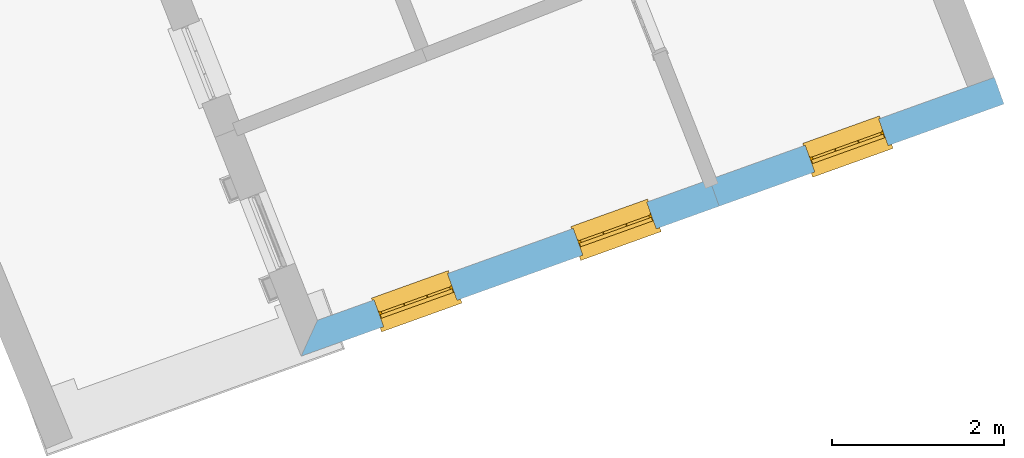
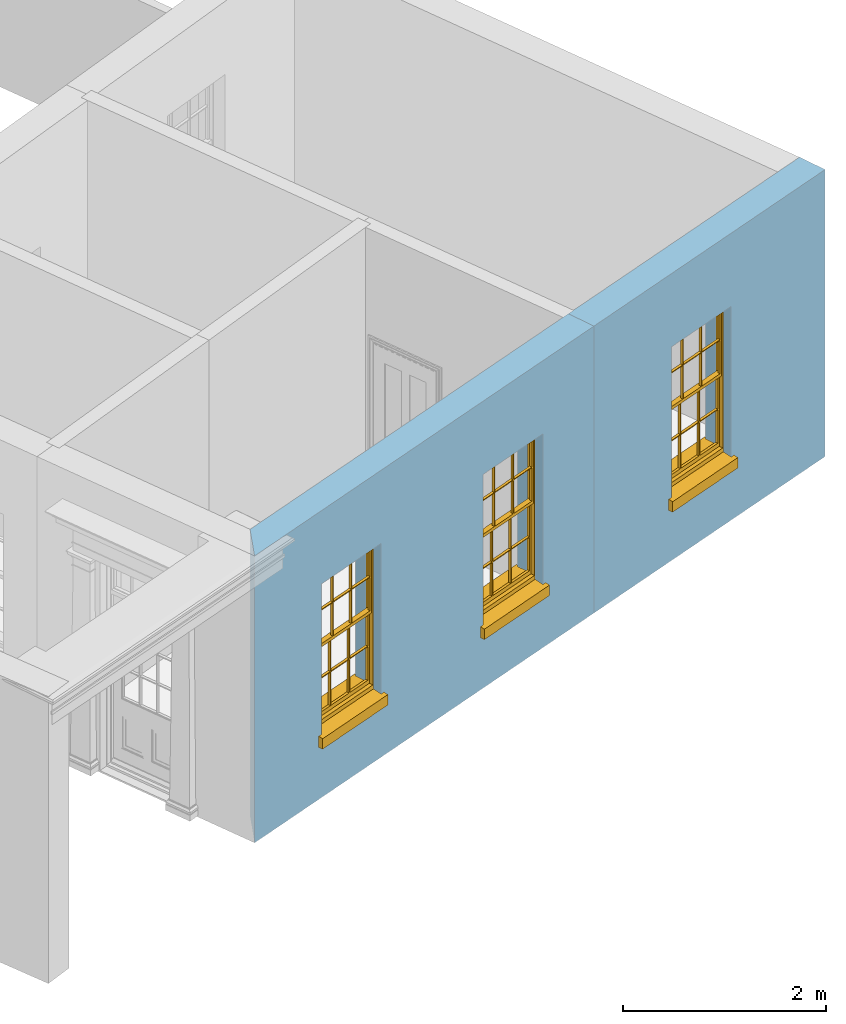
# One storey, part 5 of 8: 3 windows, 3 openings, plus 2 elements that do not belong to this part.
"""IFC2X3 building model written with IfcOpenShell, lengths in metres."""

from ifc_helpers import new_model, si_unit, frame, origin, place, context, subcontext, project, spatial, polyline, outline, extrude, faceted_brep, material, layer, layer_set, layer_usage, element, fill, save


model = new_model("IFC2X3")

# Units and contexts
model_context = context("Model", 3, world=origin())
body_context = subcontext(model_context, "Body", "Model", "MODEL_VIEW")
ifc_project = project(units=[si_unit("PLANEANGLEUNIT", "RADIAN"), si_unit("MASSUNIT", "GRAM", prefix="KILO"), si_unit("FORCEUNIT", "NEWTON", prefix="KILO"), si_unit("LENGTHUNIT", "METRE")], contexts=[model_context])

# Site, building, storey
site_placement = place(None, origin())
site = spatial("IfcSite", under=ifc_project, at=site_placement, CompositionType="ELEMENT")
building_placement = place(None, origin())
building = spatial("IfcBuilding", under=site, at=building_placement, Name="Building plot-4", CompositionType="ELEMENT")
storey_placement = place(None, frame((0.0, 0.0, 3.0)))
storey = spatial("IfcBuildingStorey", under=building, at=storey_placement, Name="Floor 0", CompositionType="ELEMENT", Elevation=3.0)

# Wall, openings, windows
ifc_material = material(Name="Masonry")
ifc_layer = layer(ifc_material, 0.33, ventilated=False)
ifc_layer_set = layer_set([ifc_layer], Name="My Wall")
ifc_layer_usage = layer_usage(ifc_layer_set, "AXIS2", "NEGATIVE", 0.08)
wall_1_placement = place(storey_placement, origin())
wall_1 = element("IfcWallStandardCase", 1, at=wall_1_placement, inside=storey, material=ifc_layer_usage, Name="exterior", context=body_context, shape_type="SweptSolid", body=[
    extrude(outline(polyline([(49.6658207886794, 46.5658070335138), (49.476039218613, 46.1471210314907), (54.3439530966588, 47.8936249571326), (54.2325115600524, 48.2042385175559), (49.6658207886794, 46.5658070335138)])), origin(), (0.0, 0.0, 1.0), 3.45),
])
opening_1_placement = place(storey_placement, frame((0.0, 0.0, 0.75)))
opening_1 = element("IfcOpeningElement", 2, at=opening_1_placement, cuts=wall_1, Name="Opening", ObjectType="Opening", context=body_context, shape_type="SweptSolid", body=[
    extrude(outline(polyline([(50.4358969684534, 46.4914975693984), (51.2924373926509, 46.7988060491311), (51.1809958560445, 47.1094196095543), (50.3244554318471, 46.8021111298216), (50.4358969684534, 46.4914975693984)])), origin(), (0.0, 0.0, 1.0), 1.82),
])
opening_2_placement = place(storey_placement, frame((0.0, 0.0, 0.75)))
opening_2 = element("IfcOpeningElement", 3, at=opening_2_placement, cuts=wall_1, Name="Opening", ObjectType="Opening", context=body_context, shape_type="SweptSolid", body=[
    extrude(outline(polyline([(52.7557542458578, 47.3238130013103), (53.6122946700553, 47.631121481043), (53.5008531334489, 47.9417350414663), (52.6443127092515, 47.6344265617336), (52.7557542458578, 47.3238130013103)])), origin(), (0.0, 0.0, 1.0), 1.82),
])
window_1_placement = place(storey_placement, frame((50.3514715619335, 46.7268108727493, 0.75), z_axis=(0.0, 0.0, 1.0), x_axis=(0.856540424197469, 0.307308479732683, 0.0)))
window_1 = element("IfcWindow", 4, at=window_1_placement, inside=storey, Name="circulation street window", OverallHeight=1.82, OverallWidth=0.91, context=body_context, shape_type="Brep", held_by="IfcProductRepresentation", body=[
    faceted_brep([(0.033125, -0.105, 0.975209), (0.01, -0.105, 0.975209), (0.033125, -0.105, 1.376042), (0.876875, -0.105, 0.975209), (0.876875, -0.105, 1.376042), (0.9, -0.105, 0.975209), (0.876875, -0.105, 1.386042), (0.876875, -0.105, 1.786875), (0.9, -0.105, 1.81), (0.033125, -0.105, 1.786875), (0.033125, -0.105, 1.386042), (0.01, -0.105, 1.81), (0.876875, -0.135, 1.376042), (0.876875, -0.135, 0.975209), (0.9, -0.135, 0.937083), (0.033125, -0.135, 1.786875), (0.01, -0.135, 1.81), (0.033125, -0.135, 1.386042), (0.01, -0.135, 0.937083), (0.033125, -0.135, 0.975209), (0.033125, -0.135, 1.376042), (0.876875, -0.135, 1.786875), (0.876875, -0.135, 1.386042), (0.9, -0.135, 1.81), (0.033125, -0.105, 0.937083), (0.01, -0.105, 0.937083), (0.033125, -0.105, 0.53625), (0.876875, -0.105, 0.937083), (0.876875, -0.105, 0.53625), (0.9, -0.105, 0.937083), (0.876875, -0.105, 0.52625), (0.876875, -0.105, 0.125417), (0.9, -0.105, 0.077167), (0.033125, -0.105, 0.125417), (0.033125, -0.105, 0.52625), (0.01, -0.105, 0.077167), (-0.0425, -0.25, 0.01), (-0.0425, -0.3, 0.001667), (0.0, -0.25, 0.01), (0.9525, -0.25, 0.01), (0.91, -0.25, 0.01), (0.9525, -0.3, 0.001667), (-0.02, 0.08, 0.077167), (0.0, 0.08, 0.077167), (-0.02, 0.11, 0.077167), (0.0, -0.06, 0.077167), (0.01, -0.06, 0.077167), (0.91, -0.06, 0.077167), (0.91, 0.08, 0.077167), (0.9, -0.06, 0.077167), (0.93, 0.08, 0.077167), (0.93, 0.11, 0.077167), (0.01, -0.075, 0.975209), (0.9, -0.075, 0.975209), (0.876875, -0.075, 0.125417), (0.876875, -0.075, 0.52625), (0.9, -0.075, 0.077167), (0.876875, -0.075, 0.53625), (0.876875, -0.075, 0.937083), (0.033125, -0.075, 0.125417), (0.01, -0.075, 0.077167), (0.033125, -0.075, 0.52625), (0.033125, -0.075, 0.937083), (0.033125, -0.075, 0.53625), (-0.02, 0.08, 0.052167), (-0.02, 0.11, 0.052167), (0.93, 0.11, 0.052167), (0.93, 0.08, 0.052167), (0.91, 0.08, 0.052167), (0.0, 0.08, 0.052167), (0.91, -0.15, 0.026667), (0.0, -0.15, 0.026667), (-0.0425, -0.3, -0.123333), (0.9525, -0.3, -0.123333), (-0.0425, -0.25, -0.123333), (0.9525, -0.25, -0.123333), (0.01, -0.06, 1.81), (0.9, -0.06, 1.81), (0.0, -0.06, 1.82), (0.91, -0.06, 1.82), (0.01, -0.15, 0.077167), (0.9, -0.15, 0.077167), (0.592292, -0.105, 0.125417), (0.592292, -0.075, 0.125417), (0.317708, -0.075, 0.125417), (0.317708, -0.105, 0.125417), (0.592292, -0.105, 0.53625), (0.317708, -0.105, 0.53625), (0.317708, -0.105, 0.52625), (0.592292, -0.105, 0.52625), (0.592292, -0.075, 0.53625), (0.317708, -0.075, 0.53625), (0.592292, -0.135, 1.386042), (0.592292, -0.105, 1.386042), (0.317708, -0.105, 1.386042), (0.317708, -0.135, 1.386042), (0.317708, -0.135, 1.376042), (0.592292, -0.135, 1.376042), (0.317708, -0.105, 1.376042), (0.592292, -0.105, 1.376042), (0.602292, -0.135, 1.376042), (0.592292, -0.135, 0.975209), (0.602292, -0.135, 0.975209), (0.602292, -0.105, 0.975209), (0.592292, -0.105, 0.975209), (0.602292, -0.105, 1.376042), (0.602292, -0.075, 0.53625), (0.602292, -0.105, 0.53625), (0.317708, -0.075, 0.52625), (0.307708, -0.075, 0.125417), (0.307708, -0.075, 0.52625), (0.602292, -0.075, 0.52625), (0.602292, -0.075, 0.125417), (0.592292, -0.075, 0.52625), (0.307708, -0.075, 0.53625), (0.317708, -0.075, 0.937083), (0.307708, -0.075, 0.937083), (0.602292, -0.075, 0.937083), (0.592292, -0.075, 0.937083), (0.307708, -0.105, 0.52625), (0.307708, -0.105, 0.125417), (0.307708, -0.105, 0.53625), (0.307708, -0.105, 0.937083), (0.592292, -0.105, 0.937083), (0.317708, -0.105, 0.937083), (0.602292, -0.105, 0.937083), (0.602292, -0.105, 0.52625), (0.602292, -0.105, 0.125417), (0.307708, -0.135, 1.386042), (0.307708, -0.135, 1.376042), (0.307708, -0.135, 0.975209), (0.317708, -0.135, 0.975209), (0.317708, -0.135, 1.786875), (0.307708, -0.135, 1.786875), (0.602292, -0.135, 1.786875), (0.592292, -0.135, 1.786875), (0.602292, -0.135, 1.386042), (0.602292, -0.105, 1.386042), (0.307708, -0.105, 1.386042), (0.307708, -0.105, 1.786875), (0.317708, -0.105, 1.786875), (0.592292, -0.105, 1.786875), (0.602292, -0.105, 1.786875), (0.307708, -0.105, 1.376042), (0.317708, -0.105, 0.975209), (0.307708, -0.105, 0.975209), (0.91, -0.15, 1.82), (0.9, -0.15, 1.81), (0.01, -0.15, 1.81), (0.0, -0.15, 1.82), (0.91, -0.25, 0.0), (0.0, -0.25, 0.0), (0.91, 0.08, 0.0), (0.0, 0.08, 0.0)], [[[0, 1, 2]], [[3, 4, 5]], [[6, 7, 8]], [[9, 10, 11]], [[12, 13, 14]], [[15, 16, 17]], [[18, 19, 20]], [[21, 22, 23]], [[24, 25, 26]], [[27, 28, 29]], [[30, 31, 32]], [[33, 34, 35]], [[14, 27, 29]], [[25, 24, 18]], [[36, 37, 38]], [[39, 40, 41]], [[42, 43, 44]], [[45, 46, 43]], [[47, 48, 49]], [[50, 51, 48]], [[1, 0, 52]], [[5, 53, 3]], [[54, 55, 56]], [[57, 58, 53]], [[59, 60, 61]], [[62, 63, 52]], [[48, 43, 46, 49]], [[51, 44, 43, 48]], [[64, 42, 44, 65]], [[65, 44, 51, 66]], [[66, 51, 50, 67]], [[65, 66, 68, 69]], [[60, 56, 49, 46]], [[70, 71, 38, 40]], [[37, 41, 40, 38]], [[37, 72, 73, 41]], [[74, 75, 73, 72]], [[8, 11, 76, 77]], [[76, 78, 79, 77]], [[32, 35, 80, 81]], [[81, 80, 71, 70]], [[82, 83, 84, 85]], [[86, 87, 88, 89]], [[86, 90, 91, 87]], [[92, 93, 94, 95]], [[92, 95, 96, 97]], [[96, 98, 99, 97]], [[100, 97, 101, 102]], [[103, 104, 99, 105]], [[97, 99, 104, 101]], [[102, 103, 105, 100]], [[28, 57, 106, 107]], [[108, 84, 109, 110]], [[111, 112, 83, 113]], [[114, 110, 61, 63]], [[90, 113, 108, 91]], [[115, 91, 114, 116]], [[117, 106, 90, 118]], [[111, 106, 57, 55]], [[119, 110, 109, 120]], [[34, 61, 110, 119]], [[89, 113, 83, 82]], [[88, 108, 113, 89]], [[85, 84, 108, 88]], [[121, 114, 63, 26]], [[122, 116, 114, 121]], [[123, 118, 90, 86]], [[87, 91, 115, 124]], [[107, 106, 117, 125]], [[126, 111, 55, 30]], [[127, 112, 111, 126]], [[126, 30, 28, 107]], [[88, 119, 120, 85]], [[126, 89, 82, 127]], [[125, 123, 86, 107]], [[121, 26, 34, 119]], [[124, 122, 121, 87]], [[128, 17, 20, 129]], [[96, 129, 130, 131]], [[132, 133, 128, 95]], [[134, 135, 92, 136]], [[100, 12, 22, 136]], [[137, 6, 4, 105]], [[94, 138, 139, 140]], [[137, 93, 141, 142]], [[99, 98, 94, 93]], [[143, 2, 10, 138]], [[144, 145, 143, 98]], [[129, 143, 145, 130]], [[20, 2, 143, 129]], [[131, 144, 98, 96]], [[128, 138, 10, 17]], [[133, 139, 138, 128]], [[135, 141, 93, 92]], [[95, 94, 140, 132]], [[22, 6, 137, 136]], [[136, 137, 142, 134]], [[100, 105, 4, 12]], [[107, 86, 89, 126]], [[106, 111, 113, 90]], [[91, 108, 110, 114]], [[87, 121, 119, 88]], [[97, 100, 136, 92]], [[129, 96, 95, 128]], [[98, 143, 138, 94]], [[105, 99, 93, 137]], [[131, 101, 104, 144]], [[124, 115, 118, 123]], [[132, 140, 141, 135]], [[120, 109, 59, 33]], [[15, 9, 139, 133]], [[134, 142, 7, 21]], [[31, 54, 112, 127]], [[36, 74, 72, 37]], [[39, 41, 73, 75]], [[18, 14, 101, 131]], [[23, 16, 132, 135]], [[83, 56, 60, 84]], [[52, 53, 118, 115]], [[53, 52, 144, 104]], [[11, 8, 141, 140]], [[14, 18, 124, 123]], [[2, 1, 11, 10]], [[8, 5, 4, 6]], [[57, 53, 56, 55]], [[60, 52, 63, 61]], [[26, 25, 35, 34]], [[32, 29, 28, 30]], [[14, 23, 22, 12]], [[18, 20, 17, 16]], [[19, 0, 2, 20]], [[17, 10, 9, 15]], [[12, 4, 3, 13]], [[21, 7, 6, 22]], [[27, 58, 57, 28]], [[30, 55, 54, 31]], [[33, 59, 61, 34]], [[26, 63, 62, 24]], [[5, 8, 77, 53]], [[76, 11, 1, 52]], [[46, 45, 78, 76]], [[49, 77, 79, 47]], [[70, 146, 147, 81]], [[71, 80, 148, 149]], [[19, 130, 145, 0]], [[102, 13, 3, 103]], [[116, 122, 24, 62]], [[29, 32, 81, 14]], [[80, 35, 25, 18]], [[60, 46, 76, 52]], [[77, 49, 56, 53]], [[23, 14, 81, 147]], [[16, 148, 80, 18]], [[35, 85, 120]], [[120, 33, 35]], [[127, 82, 32]], [[32, 31, 127]], [[32, 82, 85, 35]], [[102, 101, 14]], [[14, 13, 102]], [[18, 131, 130]], [[130, 19, 18]], [[134, 21, 23]], [[23, 135, 134]], [[16, 15, 133]], [[133, 132, 16]], [[11, 140, 139]], [[139, 9, 11]], [[142, 141, 8]], [[8, 7, 142]], [[23, 147, 148, 16]], [[146, 149, 148, 147]], [[52, 115, 116]], [[116, 62, 52]], [[118, 53, 117]], [[58, 117, 53]], [[27, 125, 117, 58]], [[56, 83, 112]], [[112, 54, 56]], [[109, 84, 60]], [[60, 59, 109]], [[125, 27, 14]], [[14, 123, 125]], [[122, 124, 18]], [[18, 24, 122]], [[145, 144, 52]], [[52, 0, 145]], [[103, 3, 53]], [[53, 104, 103]], [[79, 78, 149, 146]], [[78, 45, 71, 149]], [[146, 70, 47, 79]], [[150, 75, 74, 151]], [[68, 66, 67]], [[48, 68, 67, 50]], [[69, 64, 65]], [[42, 64, 69, 43]], [[69, 68, 152, 153]], [[70, 68, 48, 47]], [[150, 152, 68, 70]], [[43, 69, 71, 45]], [[69, 153, 151, 71]], [[152, 150, 151, 153]], [[38, 151, 74, 36]], [[71, 151, 38]], [[39, 75, 150, 40]], [[40, 150, 70]]]),
])
fill(opening_1, window_1)
window_2_placement = place(storey_placement, frame((52.6713288393379, 47.5591263046613, 0.75), z_axis=(0.0, 0.0, 1.0), x_axis=(0.856540424197469, 0.307308479732697, 0.0)))
window_2 = element("IfcWindow", 5, at=window_2_placement, inside=storey, Name="circulation street window", OverallHeight=1.82, OverallWidth=0.91, context=body_context, shape_type="Brep", held_by="IfcProductRepresentation", body=[
    faceted_brep([(0.033125, -0.105, 0.975209), (0.01, -0.105, 0.975209), (0.033125, -0.105, 1.376042), (0.876875, -0.105, 0.975209), (0.876875, -0.105, 1.376042), (0.9, -0.105, 0.975209), (0.876875, -0.105, 1.386042), (0.876875, -0.105, 1.786875), (0.9, -0.105, 1.81), (0.033125, -0.105, 1.786875), (0.033125, -0.105, 1.386042), (0.01, -0.105, 1.81), (0.876875, -0.135, 1.376042), (0.876875, -0.135, 0.975209), (0.9, -0.135, 0.937083), (0.033125, -0.135, 1.786875), (0.01, -0.135, 1.81), (0.033125, -0.135, 1.386042), (0.01, -0.135, 0.937083), (0.033125, -0.135, 0.975209), (0.033125, -0.135, 1.376042), (0.876875, -0.135, 1.786875), (0.876875, -0.135, 1.386042), (0.9, -0.135, 1.81), (0.033125, -0.105, 0.937083), (0.01, -0.105, 0.937083), (0.033125, -0.105, 0.53625), (0.876875, -0.105, 0.937083), (0.876875, -0.105, 0.53625), (0.9, -0.105, 0.937083), (0.876875, -0.105, 0.52625), (0.876875, -0.105, 0.125417), (0.9, -0.105, 0.077167), (0.033125, -0.105, 0.125417), (0.033125, -0.105, 0.52625), (0.01, -0.105, 0.077167), (-0.0425, -0.25, 0.01), (-0.0425, -0.3, 0.001667), (0.0, -0.25, 0.01), (0.9525, -0.25, 0.01), (0.91, -0.25, 0.01), (0.9525, -0.3, 0.001667), (-0.02, 0.08, 0.077167), (0.0, 0.08, 0.077167), (-0.02, 0.11, 0.077167), (0.0, -0.06, 0.077167), (0.01, -0.06, 0.077167), (0.91, -0.06, 0.077167), (0.91, 0.08, 0.077167), (0.9, -0.06, 0.077167), (0.93, 0.08, 0.077167), (0.93, 0.11, 0.077167), (0.01, -0.075, 0.975209), (0.9, -0.075, 0.975209), (0.876875, -0.075, 0.125417), (0.876875, -0.075, 0.52625), (0.9, -0.075, 0.077167), (0.876875, -0.075, 0.53625), (0.876875, -0.075, 0.937083), (0.033125, -0.075, 0.125417), (0.01, -0.075, 0.077167), (0.033125, -0.075, 0.52625), (0.033125, -0.075, 0.937083), (0.033125, -0.075, 0.53625), (-0.02, 0.08, 0.052167), (-0.02, 0.11, 0.052167), (0.93, 0.11, 0.052167), (0.93, 0.08, 0.052167), (0.91, 0.08, 0.052167), (0.0, 0.08, 0.052167), (0.91, -0.15, 0.026667), (0.0, -0.15, 0.026667), (-0.0425, -0.3, -0.123333), (0.9525, -0.3, -0.123333), (-0.0425, -0.25, -0.123333), (0.9525, -0.25, -0.123333), (0.01, -0.06, 1.81), (0.9, -0.06, 1.81), (0.0, -0.06, 1.82), (0.91, -0.06, 1.82), (0.01, -0.15, 0.077167), (0.9, -0.15, 0.077167), (0.592292, -0.105, 0.125417), (0.592292, -0.075, 0.125417), (0.317708, -0.075, 0.125417), (0.317708, -0.105, 0.125417), (0.592292, -0.105, 0.53625), (0.317708, -0.105, 0.53625), (0.317708, -0.105, 0.52625), (0.592292, -0.105, 0.52625), (0.592292, -0.075, 0.53625), (0.317708, -0.075, 0.53625), (0.592292, -0.135, 1.386042), (0.592292, -0.105, 1.386042), (0.317708, -0.105, 1.386042), (0.317708, -0.135, 1.386042), (0.317708, -0.135, 1.376042), (0.592292, -0.135, 1.376042), (0.317708, -0.105, 1.376042), (0.592292, -0.105, 1.376042), (0.602292, -0.135, 1.376042), (0.592292, -0.135, 0.975209), (0.602292, -0.135, 0.975209), (0.602292, -0.105, 0.975209), (0.592292, -0.105, 0.975209), (0.602292, -0.105, 1.376042), (0.602292, -0.075, 0.53625), (0.602292, -0.105, 0.53625), (0.317708, -0.075, 0.52625), (0.307708, -0.075, 0.125417), (0.307708, -0.075, 0.52625), (0.602292, -0.075, 0.52625), (0.602292, -0.075, 0.125417), (0.592292, -0.075, 0.52625), (0.307708, -0.075, 0.53625), (0.317708, -0.075, 0.937083), (0.307708, -0.075, 0.937083), (0.602292, -0.075, 0.937083), (0.592292, -0.075, 0.937083), (0.307708, -0.105, 0.52625), (0.307708, -0.105, 0.125417), (0.307708, -0.105, 0.53625), (0.307708, -0.105, 0.937083), (0.592292, -0.105, 0.937083), (0.317708, -0.105, 0.937083), (0.602292, -0.105, 0.937083), (0.602292, -0.105, 0.52625), (0.602292, -0.105, 0.125417), (0.307708, -0.135, 1.386042), (0.307708, -0.135, 1.376042), (0.307708, -0.135, 0.975209), (0.317708, -0.135, 0.975209), (0.317708, -0.135, 1.786875), (0.307708, -0.135, 1.786875), (0.602292, -0.135, 1.786875), (0.592292, -0.135, 1.786875), (0.602292, -0.135, 1.386042), (0.602292, -0.105, 1.386042), (0.307708, -0.105, 1.386042), (0.307708, -0.105, 1.786875), (0.317708, -0.105, 1.786875), (0.592292, -0.105, 1.786875), (0.602292, -0.105, 1.786875), (0.307708, -0.105, 1.376042), (0.317708, -0.105, 0.975209), (0.307708, -0.105, 0.975209), (0.91, -0.15, 1.82), (0.9, -0.15, 1.81), (0.01, -0.15, 1.81), (0.0, -0.15, 1.82), (0.91, -0.25, 0.0), (0.0, -0.25, 0.0), (0.91, 0.08, 0.0), (0.0, 0.08, 0.0)], [[[0, 1, 2]], [[3, 4, 5]], [[6, 7, 8]], [[9, 10, 11]], [[12, 13, 14]], [[15, 16, 17]], [[18, 19, 20]], [[21, 22, 23]], [[24, 25, 26]], [[27, 28, 29]], [[30, 31, 32]], [[33, 34, 35]], [[14, 27, 29]], [[25, 24, 18]], [[36, 37, 38]], [[39, 40, 41]], [[42, 43, 44]], [[45, 46, 43]], [[47, 48, 49]], [[50, 51, 48]], [[1, 0, 52]], [[5, 53, 3]], [[54, 55, 56]], [[57, 58, 53]], [[59, 60, 61]], [[62, 63, 52]], [[48, 43, 46, 49]], [[51, 44, 43, 48]], [[64, 42, 44, 65]], [[65, 44, 51, 66]], [[66, 51, 50, 67]], [[65, 66, 68, 69]], [[60, 56, 49, 46]], [[70, 71, 38, 40]], [[37, 41, 40, 38]], [[37, 72, 73, 41]], [[74, 75, 73, 72]], [[8, 11, 76, 77]], [[76, 78, 79, 77]], [[32, 35, 80, 81]], [[81, 80, 71, 70]], [[82, 83, 84, 85]], [[86, 87, 88, 89]], [[86, 90, 91, 87]], [[92, 93, 94, 95]], [[92, 95, 96, 97]], [[96, 98, 99, 97]], [[100, 97, 101, 102]], [[103, 104, 99, 105]], [[97, 99, 104, 101]], [[102, 103, 105, 100]], [[28, 57, 106, 107]], [[108, 84, 109, 110]], [[111, 112, 83, 113]], [[114, 110, 61, 63]], [[90, 113, 108, 91]], [[115, 91, 114, 116]], [[117, 106, 90, 118]], [[111, 106, 57, 55]], [[119, 110, 109, 120]], [[34, 61, 110, 119]], [[89, 113, 83, 82]], [[88, 108, 113, 89]], [[85, 84, 108, 88]], [[121, 114, 63, 26]], [[122, 116, 114, 121]], [[123, 118, 90, 86]], [[87, 91, 115, 124]], [[107, 106, 117, 125]], [[126, 111, 55, 30]], [[127, 112, 111, 126]], [[126, 30, 28, 107]], [[88, 119, 120, 85]], [[126, 89, 82, 127]], [[125, 123, 86, 107]], [[121, 26, 34, 119]], [[124, 122, 121, 87]], [[128, 17, 20, 129]], [[96, 129, 130, 131]], [[132, 133, 128, 95]], [[134, 135, 92, 136]], [[100, 12, 22, 136]], [[137, 6, 4, 105]], [[94, 138, 139, 140]], [[137, 93, 141, 142]], [[99, 98, 94, 93]], [[143, 2, 10, 138]], [[144, 145, 143, 98]], [[129, 143, 145, 130]], [[20, 2, 143, 129]], [[131, 144, 98, 96]], [[128, 138, 10, 17]], [[133, 139, 138, 128]], [[135, 141, 93, 92]], [[95, 94, 140, 132]], [[22, 6, 137, 136]], [[136, 137, 142, 134]], [[100, 105, 4, 12]], [[107, 86, 89, 126]], [[106, 111, 113, 90]], [[91, 108, 110, 114]], [[87, 121, 119, 88]], [[97, 100, 136, 92]], [[129, 96, 95, 128]], [[98, 143, 138, 94]], [[105, 99, 93, 137]], [[131, 101, 104, 144]], [[124, 115, 118, 123]], [[132, 140, 141, 135]], [[120, 109, 59, 33]], [[15, 9, 139, 133]], [[134, 142, 7, 21]], [[31, 54, 112, 127]], [[36, 74, 72, 37]], [[39, 41, 73, 75]], [[18, 14, 101, 131]], [[23, 16, 132, 135]], [[83, 56, 60, 84]], [[52, 53, 118, 115]], [[53, 52, 144, 104]], [[11, 8, 141, 140]], [[14, 18, 124, 123]], [[2, 1, 11, 10]], [[8, 5, 4, 6]], [[57, 53, 56, 55]], [[60, 52, 63, 61]], [[26, 25, 35, 34]], [[32, 29, 28, 30]], [[14, 23, 22, 12]], [[18, 20, 17, 16]], [[19, 0, 2, 20]], [[17, 10, 9, 15]], [[12, 4, 3, 13]], [[21, 7, 6, 22]], [[27, 58, 57, 28]], [[30, 55, 54, 31]], [[33, 59, 61, 34]], [[26, 63, 62, 24]], [[5, 8, 77, 53]], [[76, 11, 1, 52]], [[46, 45, 78, 76]], [[49, 77, 79, 47]], [[70, 146, 147, 81]], [[71, 80, 148, 149]], [[19, 130, 145, 0]], [[102, 13, 3, 103]], [[116, 122, 24, 62]], [[29, 32, 81, 14]], [[80, 35, 25, 18]], [[60, 46, 76, 52]], [[77, 49, 56, 53]], [[23, 14, 81, 147]], [[16, 148, 80, 18]], [[35, 85, 120]], [[120, 33, 35]], [[127, 82, 32]], [[32, 31, 127]], [[32, 82, 85, 35]], [[102, 101, 14]], [[14, 13, 102]], [[18, 131, 130]], [[130, 19, 18]], [[134, 21, 23]], [[23, 135, 134]], [[16, 15, 133]], [[133, 132, 16]], [[11, 140, 139]], [[139, 9, 11]], [[142, 141, 8]], [[8, 7, 142]], [[23, 147, 148, 16]], [[146, 149, 148, 147]], [[52, 115, 116]], [[116, 62, 52]], [[118, 53, 117]], [[58, 117, 53]], [[27, 125, 117, 58]], [[56, 83, 112]], [[112, 54, 56]], [[109, 84, 60]], [[60, 59, 109]], [[125, 27, 14]], [[14, 123, 125]], [[122, 124, 18]], [[18, 24, 122]], [[145, 144, 52]], [[52, 0, 145]], [[103, 3, 53]], [[53, 104, 103]], [[79, 78, 149, 146]], [[78, 45, 71, 149]], [[146, 70, 47, 79]], [[150, 75, 74, 151]], [[68, 66, 67]], [[48, 68, 67, 50]], [[69, 64, 65]], [[42, 64, 69, 43]], [[69, 68, 152, 153]], [[70, 68, 48, 47]], [[150, 152, 68, 70]], [[43, 69, 71, 45]], [[69, 153, 151, 71]], [[152, 150, 151, 153]], [[38, 151, 74, 36]], [[71, 151, 38]], [[39, 75, 150, 40]], [[40, 150, 70]]]),
])
fill(opening_2, window_2)

# Wall, opening, window
wall_2_placement = place(storey_placement, origin())
wall_2 = element("IfcWallStandardCase", 6, at=wall_2_placement, inside=storey, material=ifc_layer_usage, Name="exterior", context=body_context, shape_type="SweptSolid", body=[
    extrude(outline(polyline([(54.2325115600524, 48.2042385175559), (54.3439530966588, 47.8936249571326), (57.6606145588137, 49.0835725216947), (57.5491730222074, 49.394186082118), (54.2325115600524, 48.2042385175559)])), origin(), (0.0, 0.0, 1.0), 3.45),
])
opening_3_placement = place(storey_placement, frame((0.0, 0.0, 0.75)))
opening_3 = element("IfcOpeningElement", 7, at=opening_3_placement, cuts=wall_2, Name="Opening", ObjectType="Opening", context=body_context, shape_type="SweptSolid", body=[
    extrude(outline(polyline([(55.456356963962, 48.2927317962874), (56.3128973881595, 48.60004027602), (56.2014558515532, 48.9106538364433), (55.3449154273557, 48.6033453567106), (55.456356963962, 48.2927317962874)])), origin(), (0.0, 0.0, 1.0), 1.82),
])
window_3_placement = place(storey_placement, frame((55.3719315574421, 48.5280450996383, 0.75), z_axis=(0.0, 0.0, 1.0), x_axis=(0.856540424197483, 0.307308479732662, 0.0)))
window_3 = element("IfcWindow", 8, at=window_3_placement, inside=storey, Name="living street window", OverallHeight=1.82, OverallWidth=0.91, context=body_context, shape_type="Brep", held_by="IfcProductRepresentation", body=[
    faceted_brep([(0.033125, -0.105, 0.975209), (0.01, -0.105, 0.975209), (0.033125, -0.105, 1.376042), (0.876875, -0.105, 0.975209), (0.876875, -0.105, 1.376042), (0.9, -0.105, 0.975209), (0.876875, -0.105, 1.386042), (0.876875, -0.105, 1.786875), (0.9, -0.105, 1.81), (0.033125, -0.105, 1.786875), (0.033125, -0.105, 1.386042), (0.01, -0.105, 1.81), (0.876875, -0.135, 1.376042), (0.876875, -0.135, 0.975209), (0.9, -0.135, 0.937083), (0.033125, -0.135, 1.786875), (0.01, -0.135, 1.81), (0.033125, -0.135, 1.386042), (0.01, -0.135, 0.937083), (0.033125, -0.135, 0.975209), (0.033125, -0.135, 1.376042), (0.876875, -0.135, 1.786875), (0.876875, -0.135, 1.386042), (0.9, -0.135, 1.81), (0.033125, -0.105, 0.937083), (0.01, -0.105, 0.937083), (0.033125, -0.105, 0.53625), (0.876875, -0.105, 0.937083), (0.876875, -0.105, 0.53625), (0.9, -0.105, 0.937083), (0.876875, -0.105, 0.52625), (0.876875, -0.105, 0.125417), (0.9, -0.105, 0.077167), (0.033125, -0.105, 0.125417), (0.033125, -0.105, 0.52625), (0.01, -0.105, 0.077167), (-0.0425, -0.25, 0.01), (-0.0425, -0.3, 0.001667), (0.0, -0.25, 0.01), (0.9525, -0.25, 0.01), (0.91, -0.25, 0.01), (0.9525, -0.3, 0.001667), (-0.02, 0.08, 0.077167), (0.0, 0.08, 0.077167), (-0.02, 0.11, 0.077167), (0.0, -0.06, 0.077167), (0.01, -0.06, 0.077167), (0.91, -0.06, 0.077167), (0.91, 0.08, 0.077167), (0.9, -0.06, 0.077167), (0.93, 0.08, 0.077167), (0.93, 0.11, 0.077167), (0.01, -0.075, 0.975209), (0.9, -0.075, 0.975209), (0.876875, -0.075, 0.125417), (0.876875, -0.075, 0.52625), (0.9, -0.075, 0.077167), (0.876875, -0.075, 0.53625), (0.876875, -0.075, 0.937083), (0.033125, -0.075, 0.125417), (0.01, -0.075, 0.077167), (0.033125, -0.075, 0.52625), (0.033125, -0.075, 0.937083), (0.033125, -0.075, 0.53625), (-0.02, 0.08, 0.052167), (-0.02, 0.11, 0.052167), (0.93, 0.11, 0.052167), (0.93, 0.08, 0.052167), (0.91, 0.08, 0.052167), (0.0, 0.08, 0.052167), (0.91, -0.15, 0.026667), (0.0, -0.15, 0.026667), (-0.0425, -0.3, -0.123333), (0.9525, -0.3, -0.123333), (-0.0425, -0.25, -0.123333), (0.9525, -0.25, -0.123333), (0.01, -0.06, 1.81), (0.9, -0.06, 1.81), (0.0, -0.06, 1.82), (0.91, -0.06, 1.82), (0.01, -0.15, 0.077167), (0.9, -0.15, 0.077167), (0.592292, -0.105, 0.125417), (0.592292, -0.075, 0.125417), (0.317708, -0.075, 0.125417), (0.317708, -0.105, 0.125417), (0.592292, -0.105, 0.53625), (0.317708, -0.105, 0.53625), (0.317708, -0.105, 0.52625), (0.592292, -0.105, 0.52625), (0.592292, -0.075, 0.53625), (0.317708, -0.075, 0.53625), (0.592292, -0.135, 1.386042), (0.592292, -0.105, 1.386042), (0.317708, -0.105, 1.386042), (0.317708, -0.135, 1.386042), (0.317708, -0.135, 1.376042), (0.592292, -0.135, 1.376042), (0.317708, -0.105, 1.376042), (0.592292, -0.105, 1.376042), (0.602292, -0.135, 1.376042), (0.592292, -0.135, 0.975209), (0.602292, -0.135, 0.975209), (0.602292, -0.105, 0.975209), (0.592292, -0.105, 0.975209), (0.602292, -0.105, 1.376042), (0.602292, -0.075, 0.53625), (0.602292, -0.105, 0.53625), (0.317708, -0.075, 0.52625), (0.307708, -0.075, 0.125417), (0.307708, -0.075, 0.52625), (0.602292, -0.075, 0.52625), (0.602292, -0.075, 0.125417), (0.592292, -0.075, 0.52625), (0.307708, -0.075, 0.53625), (0.317708, -0.075, 0.937083), (0.307708, -0.075, 0.937083), (0.602292, -0.075, 0.937083), (0.592292, -0.075, 0.937083), (0.307708, -0.105, 0.52625), (0.307708, -0.105, 0.125417), (0.307708, -0.105, 0.53625), (0.307708, -0.105, 0.937083), (0.592292, -0.105, 0.937083), (0.317708, -0.105, 0.937083), (0.602292, -0.105, 0.937083), (0.602292, -0.105, 0.52625), (0.602292, -0.105, 0.125417), (0.307708, -0.135, 1.386042), (0.307708, -0.135, 1.376042), (0.307708, -0.135, 0.975209), (0.317708, -0.135, 0.975209), (0.317708, -0.135, 1.786875), (0.307708, -0.135, 1.786875), (0.602292, -0.135, 1.786875), (0.592292, -0.135, 1.786875), (0.602292, -0.135, 1.386042), (0.602292, -0.105, 1.386042), (0.307708, -0.105, 1.386042), (0.307708, -0.105, 1.786875), (0.317708, -0.105, 1.786875), (0.592292, -0.105, 1.786875), (0.602292, -0.105, 1.786875), (0.307708, -0.105, 1.376042), (0.317708, -0.105, 0.975209), (0.307708, -0.105, 0.975209), (0.91, -0.15, 1.82), (0.9, -0.15, 1.81), (0.01, -0.15, 1.81), (0.0, -0.15, 1.82), (0.91, -0.25, 0.0), (0.0, -0.25, 0.0), (0.91, 0.08, 0.0), (0.0, 0.08, 0.0)], [[[0, 1, 2]], [[3, 4, 5]], [[6, 7, 8]], [[9, 10, 11]], [[12, 13, 14]], [[15, 16, 17]], [[18, 19, 20]], [[21, 22, 23]], [[24, 25, 26]], [[27, 28, 29]], [[30, 31, 32]], [[33, 34, 35]], [[14, 27, 29]], [[25, 24, 18]], [[36, 37, 38]], [[39, 40, 41]], [[42, 43, 44]], [[45, 46, 43]], [[47, 48, 49]], [[50, 51, 48]], [[1, 0, 52]], [[5, 53, 3]], [[54, 55, 56]], [[57, 58, 53]], [[59, 60, 61]], [[62, 63, 52]], [[48, 43, 46, 49]], [[51, 44, 43, 48]], [[64, 42, 44, 65]], [[65, 44, 51, 66]], [[66, 51, 50, 67]], [[65, 66, 68, 69]], [[60, 56, 49, 46]], [[70, 71, 38, 40]], [[37, 41, 40, 38]], [[37, 72, 73, 41]], [[74, 75, 73, 72]], [[8, 11, 76, 77]], [[76, 78, 79, 77]], [[32, 35, 80, 81]], [[81, 80, 71, 70]], [[82, 83, 84, 85]], [[86, 87, 88, 89]], [[86, 90, 91, 87]], [[92, 93, 94, 95]], [[92, 95, 96, 97]], [[96, 98, 99, 97]], [[100, 97, 101, 102]], [[103, 104, 99, 105]], [[97, 99, 104, 101]], [[102, 103, 105, 100]], [[28, 57, 106, 107]], [[108, 84, 109, 110]], [[111, 112, 83, 113]], [[114, 110, 61, 63]], [[90, 113, 108, 91]], [[115, 91, 114, 116]], [[117, 106, 90, 118]], [[111, 106, 57, 55]], [[119, 110, 109, 120]], [[34, 61, 110, 119]], [[89, 113, 83, 82]], [[88, 108, 113, 89]], [[85, 84, 108, 88]], [[121, 114, 63, 26]], [[122, 116, 114, 121]], [[123, 118, 90, 86]], [[87, 91, 115, 124]], [[107, 106, 117, 125]], [[126, 111, 55, 30]], [[127, 112, 111, 126]], [[126, 30, 28, 107]], [[88, 119, 120, 85]], [[126, 89, 82, 127]], [[125, 123, 86, 107]], [[121, 26, 34, 119]], [[124, 122, 121, 87]], [[128, 17, 20, 129]], [[96, 129, 130, 131]], [[132, 133, 128, 95]], [[134, 135, 92, 136]], [[100, 12, 22, 136]], [[137, 6, 4, 105]], [[94, 138, 139, 140]], [[137, 93, 141, 142]], [[99, 98, 94, 93]], [[143, 2, 10, 138]], [[144, 145, 143, 98]], [[129, 143, 145, 130]], [[20, 2, 143, 129]], [[131, 144, 98, 96]], [[128, 138, 10, 17]], [[133, 139, 138, 128]], [[135, 141, 93, 92]], [[95, 94, 140, 132]], [[22, 6, 137, 136]], [[136, 137, 142, 134]], [[100, 105, 4, 12]], [[107, 86, 89, 126]], [[106, 111, 113, 90]], [[91, 108, 110, 114]], [[87, 121, 119, 88]], [[97, 100, 136, 92]], [[129, 96, 95, 128]], [[98, 143, 138, 94]], [[105, 99, 93, 137]], [[131, 101, 104, 144]], [[124, 115, 118, 123]], [[132, 140, 141, 135]], [[120, 109, 59, 33]], [[15, 9, 139, 133]], [[134, 142, 7, 21]], [[31, 54, 112, 127]], [[36, 74, 72, 37]], [[39, 41, 73, 75]], [[18, 14, 101, 131]], [[23, 16, 132, 135]], [[83, 56, 60, 84]], [[52, 53, 118, 115]], [[53, 52, 144, 104]], [[11, 8, 141, 140]], [[14, 18, 124, 123]], [[2, 1, 11, 10]], [[8, 5, 4, 6]], [[57, 53, 56, 55]], [[60, 52, 63, 61]], [[26, 25, 35, 34]], [[32, 29, 28, 30]], [[14, 23, 22, 12]], [[18, 20, 17, 16]], [[19, 0, 2, 20]], [[17, 10, 9, 15]], [[12, 4, 3, 13]], [[21, 7, 6, 22]], [[27, 58, 57, 28]], [[30, 55, 54, 31]], [[33, 59, 61, 34]], [[26, 63, 62, 24]], [[5, 8, 77, 53]], [[76, 11, 1, 52]], [[46, 45, 78, 76]], [[49, 77, 79, 47]], [[70, 146, 147, 81]], [[71, 80, 148, 149]], [[19, 130, 145, 0]], [[102, 13, 3, 103]], [[116, 122, 24, 62]], [[29, 32, 81, 14]], [[80, 35, 25, 18]], [[60, 46, 76, 52]], [[77, 49, 56, 53]], [[23, 14, 81, 147]], [[16, 148, 80, 18]], [[35, 85, 120]], [[120, 33, 35]], [[127, 82, 32]], [[32, 31, 127]], [[32, 82, 85, 35]], [[102, 101, 14]], [[14, 13, 102]], [[18, 131, 130]], [[130, 19, 18]], [[134, 21, 23]], [[23, 135, 134]], [[16, 15, 133]], [[133, 132, 16]], [[11, 140, 139]], [[139, 9, 11]], [[142, 141, 8]], [[8, 7, 142]], [[23, 147, 148, 16]], [[146, 149, 148, 147]], [[52, 115, 116]], [[116, 62, 52]], [[118, 53, 117]], [[58, 117, 53]], [[27, 125, 117, 58]], [[56, 83, 112]], [[112, 54, 56]], [[109, 84, 60]], [[60, 59, 109]], [[125, 27, 14]], [[14, 123, 125]], [[122, 124, 18]], [[18, 24, 122]], [[145, 144, 52]], [[52, 0, 145]], [[103, 3, 53]], [[53, 104, 103]], [[79, 78, 149, 146]], [[78, 45, 71, 149]], [[146, 70, 47, 79]], [[150, 75, 74, 151]], [[68, 66, 67]], [[48, 68, 67, 50]], [[69, 64, 65]], [[42, 64, 69, 43]], [[69, 68, 152, 153]], [[70, 68, 48, 47]], [[150, 152, 68, 70]], [[43, 69, 71, 45]], [[69, 153, 151, 71]], [[152, 150, 151, 153]], [[38, 151, 74, 36]], [[71, 151, 38]], [[39, 75, 150, 40]], [[40, 150, 70]]]),
])
fill(opening_3, window_3)

save(model, "model.ifc")
